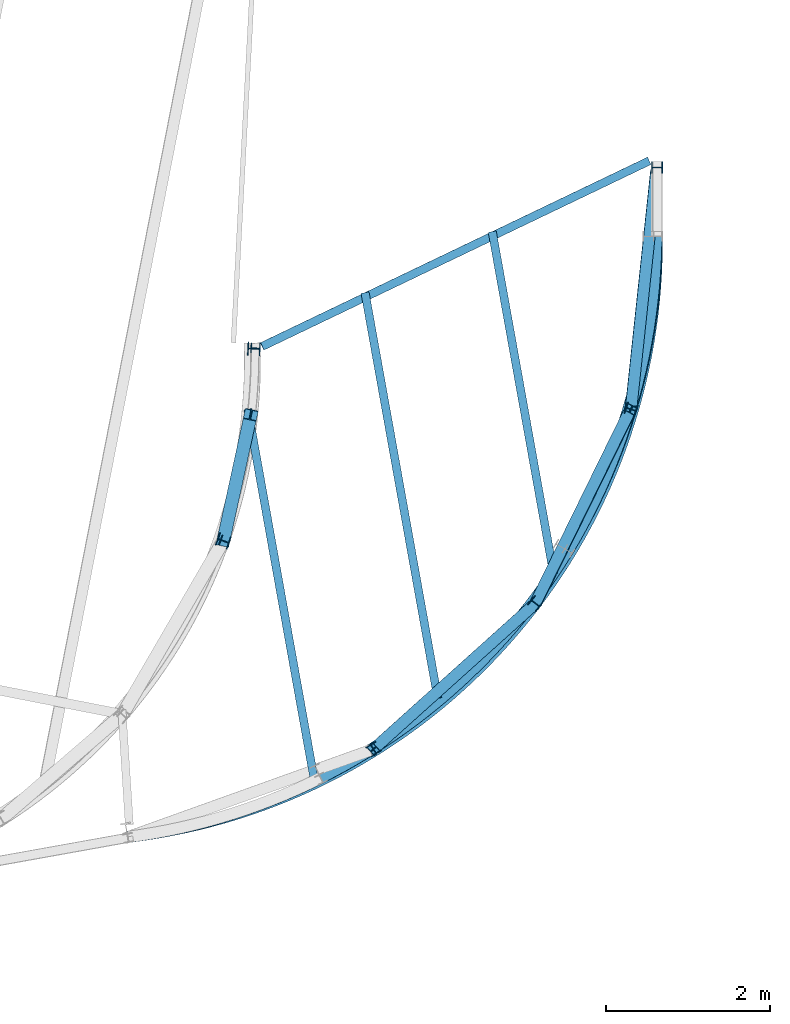
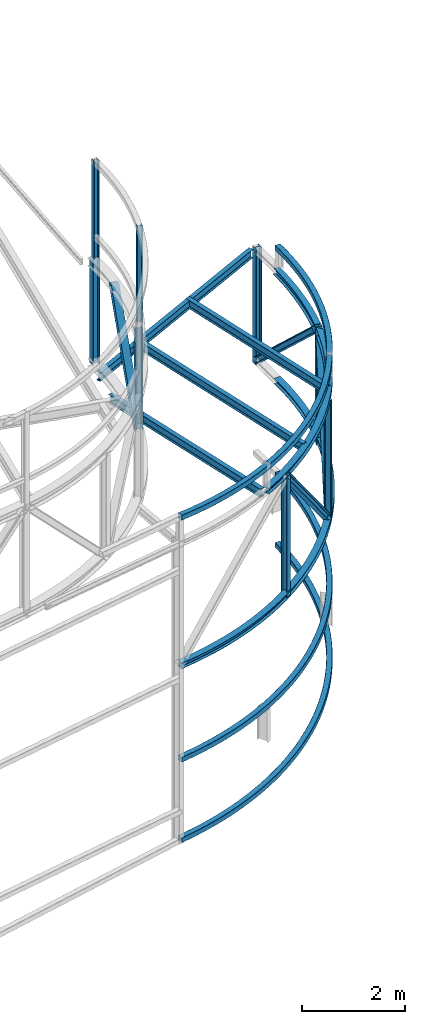
# One storey, part 103 of 215: 18 beams, 4 members, 22 elements without a shape of their own.
"""IFC2X3 building model written with IfcOpenShell, lengths in millimetres."""

from ifc_helpers import new_model, entity, si_unit, frame, origin_with_axes, origin_2d_with_axis, place, context, subcontext, project, spatial, i_section, extrude, material, type_object, element, aggregate, save


model = new_model("IFC2X3")

# Units and contexts
model_context = context("Model", 3, precision=1e-05, world=origin_with_axes())
body_context = subcontext(model_context, "Body", "Model", "MODEL_VIEW")
ifc_project = project(units=[si_unit("LENGTHUNIT", "METRE", prefix="MILLI"), si_unit("AREAUNIT", "SQUARE_METRE"), si_unit("VOLUMEUNIT", "CUBIC_METRE"), si_unit("MASSUNIT", "GRAM", prefix="KILO"), si_unit("TIMEUNIT", "SECOND"), si_unit("PLANEANGLEUNIT", "RADIAN"), si_unit("SOLIDANGLEUNIT", "STERADIAN"), si_unit("THERMODYNAMICTEMPERATUREUNIT", "DEGREE_CELSIUS"), si_unit("LUMINOUSINTENSITYUNIT", "LUMEN")], contexts=[model_context])

# Site, building, storey
site_placement = place(None, origin_with_axes())
site = spatial("IfcSite", under=ifc_project, at=site_placement, CompositionType="ELEMENT")
building_placement = place(site_placement, origin_with_axes())
building = spatial("IfcBuilding", under=site, at=building_placement, Name="Undefined", CompositionType="ELEMENT")
storey_placement = place(building_placement, origin_with_axes())
storey = spatial("IfcBuildingStorey", under=building, at=storey_placement, Name="Undefined", CompositionType="ELEMENT", Elevation=0.0)

# Assembly, beam
assembly_1_placement = place(storey_placement, origin_with_axes())
assembly_1 = element("IfcElementAssembly", 1, at=assembly_1_placement, inside=storey, Name="Steel Assembly", AssemblyPlace="NOTDEFINED", PredefinedType="RIGID_FRAME")
ifc_material = material(Name="STEEL/S275JR")
beam_type_1 = type_object("IfcBeamType", PredefinedType="NOTDEFINED")
beam_1_placement = place(assembly_1_placement, frame((103812.661912902, 11415.6337309544, 9570.9117512073), z_axis=(0.0238471140049326, 0.0280272360057927, 0.999322665206545), x_axis=(-0.657407552907123, -0.752636250893669, 0.0367965109948015)))
beam_1 = element("IfcBeam", 2, at=beam_1_placement, type_object=beam_type_1, material=ifc_material, Name="LISSE", context=body_context, shape_type="SweptSolid", body=[
    entity("IfcRevolvedAreaSolid", entity("IfcRectangleHollowProfileDef", "AREA", None, entity("IfcAxis2Placement2D", entity("IfcCartesianPoint", [0.0, 0.0]), entity("IfcDirection", [1.0, 0.0])), 120.0, 120.0, 4.0, 4.0, 8.0), entity("IfcAxis2Placement3D", entity("IfcCartesianPoint", [9816.76385710015, -1.33829753182288e-11, 3.63797880709171e-12]), entity("IfcDirection", [-0.751503806617227, 0.659728753837376, -1.25173885928287e-18]), entity("IfcDirection", [-0.659728753837376, -0.751503806617228, 1.42586860458967e-18])), entity("IfcAxis1Placement", entity("IfcCartesianPoint", [7440.0, 0.0, 0.0]), entity("IfcDirection", [0.0, 1.0, 0.0])), 1.44091553163659),
])
aggregate(assembly_1, [beam_1])

assembly_2_placement = place(storey_placement, origin_with_axes())
assembly_2 = element("IfcElementAssembly", 3, at=assembly_2_placement, inside=storey, Name="Steel Assembly", AssemblyPlace="NOTDEFINED", PredefinedType="RIGID_FRAME")
beam_type_2 = type_object("IfcBeamType", PredefinedType="NOTDEFINED")
beam_2_placement = place(assembly_2_placement, frame((97360.7958890832, 4029.22353778502, 4201.93969040489), z_axis=(-0.753149483126741, 0.657849332110703, -0.000335123000056234), x_axis=(0.657849249727944, 0.753149556688531, 0.00033149999986287)))
beam_2 = element("IfcBeam", 4, at=beam_2_placement, type_object=beam_type_2, material=ifc_material, Name="LISSE", context=body_context, shape_type="SweptSolid", body=[
    entity("IfcRevolvedAreaSolid", entity("IfcRectangleHollowProfileDef", "AREA", None, entity("IfcAxis2Placement2D", entity("IfcCartesianPoint", [0.0, 0.0]), entity("IfcDirection", [1.0, 0.0])), 120.0, 120.0, 5.0, 5.0, 10.0), entity("IfcAxis2Placement3D", entity("IfcCartesianPoint", [9809.51752939586, -1.06355002164056e-15, 1.2093029828155e-12]), entity("IfcDirection", [-0.751931040331638, 8.15245267486847e-20, -0.659241769448646]), entity("IfcDirection", [-6.93889390390723e-18, -1.0, -3.46944695195361e-18])), entity("IfcAxis1Placement", entity("IfcCartesianPoint", [0.0, 7440.0, 0.0]), entity("IfcDirection", [-1.0, 0.0, 0.0])), 1.43961987357017),
])
aggregate(assembly_2, [beam_2])

assembly_3_placement = place(storey_placement, origin_with_axes())
assembly_3 = element("IfcElementAssembly", 5, at=assembly_3_placement, inside=storey, Name="Steel Assembly", AssemblyPlace="NOTDEFINED", PredefinedType="RIGID_FRAME")
beam_3_placement = place(assembly_3_placement, frame((97359.8187777955, 4028.08994391259, 2298.41867692183), z_axis=(-0.753151991988058, 0.65784646798957, 0.000318618999995075), x_axis=(0.657653148961454, 0.752918744955869, 0.0246109559985575)))
beam_3 = element("IfcBeam", 6, at=beam_3_placement, type_object=beam_type_2, material=ifc_material, Name="LISSE", context=body_context, shape_type="SweptSolid", body=[
    entity("IfcRevolvedAreaSolid", entity("IfcRectangleHollowProfileDef", "AREA", None, entity("IfcAxis2Placement2D", entity("IfcCartesianPoint", [0.0, 0.0]), entity("IfcDirection", [1.0, 0.0])), 120.0, 120.0, 5.0, 5.0, 10.0), entity("IfcAxis2Placement3D", entity("IfcCartesianPoint", [9812.52919766532, -3.07016463649052e-13, -1.43585556658826e-11]), entity("IfcDirection", [-0.751753544225924, -2.89415736182007e-18, -0.659444166509767]), entity("IfcDirection", [-6.93889390390723e-18, -1.0, -3.46944695195361e-18])), entity("IfcAxis1Placement", entity("IfcCartesianPoint", [0.0, 7440.0, 0.0]), entity("IfcDirection", [-1.0, 0.0, 0.0])), 1.44015827653573),
])
aggregate(assembly_3, [beam_3])

# Assembly, member
assembly_4_placement = place(storey_placement, origin_with_axes())
assembly_4 = element("IfcElementAssembly", 7, at=assembly_4_placement, inside=storey, Name="Steel Assembly", AssemblyPlace="NOTDEFINED", PredefinedType="RIGID_FRAME")
member_type_1 = type_object("IfcMemberType", Name="HEA140", PredefinedType="NOTDEFINED")
member_1_placement = place(assembly_4_placement, frame((103801.363604508, 12197.8771549514, 6428.9296207433), z_axis=(0.0995443420180361, 0.662303576120042, 0.742593359134594), x_axis=(-0.078657430998341, -0.738727027984427, 0.669399272985889)))
member_1 = element("IfcMember", 8, at=member_1_placement, type_object=member_type_1, material=ifc_material, Name="LISSE", ObjectType="HEA140", context=body_context, shape_type="SweptSolid", body=[
    extrude(i_section(OverallWidth=140.0, OverallDepth=133.0, WebThickness=5.5, FlangeThickness=8.5, FilletRadius=12.0, at=origin_2d_with_axis()), frame((3988.20909249105, 1.46003443079458e-11, -6.64170234225445e-13), z_axis=(-1.0, 0.0, 0.0), x_axis=(-6.93889390390723e-18, -1.0, -3.46944695195361e-18)), (0.0, 0.0, 1.0), 3988.2),
])
aggregate(assembly_4, [member_1])

assembly_5_placement = place(storey_placement, origin_with_axes())
assembly_5 = element("IfcElementAssembly", 9, at=assembly_5_placement, inside=storey, Name="Steel Assembly", AssemblyPlace="NOTDEFINED", PredefinedType="RIGID_FRAME")
member_2_placement = place(assembly_5_placement, frame((102325.751087919, 6884.35829072175, 6427.24582166944), z_axis=(-0.354096459889119, -0.618141540806436, 0.70179536378024), x_axis=(0.309534081017408, 0.630656755035466, 0.711660530040022)))
member_2 = element("IfcMember", 10, at=member_2_placement, type_object=member_type_1, material=ifc_material, Name="LISSE", ObjectType="HEA140", context=body_context, shape_type="SweptSolid", body=[
    extrude(i_section(OverallWidth=140.0, OverallDepth=133.0, WebThickness=5.5, FlangeThickness=8.5, FilletRadius=12.0, at=origin_2d_with_axis()), frame((3753.73925143929, 2.89345262670774e-11, 0.0), z_axis=(-1.0, 0.0, 0.0), x_axis=(-6.93889390390723e-18, -1.0, -3.46944695195361e-18)), (0.0, 0.0, 1.0), 3753.7),
])
aggregate(assembly_5, [member_2])

assembly_6_placement = place(storey_placement, origin_with_axes())
assembly_6 = element("IfcElementAssembly", 11, at=assembly_6_placement, inside=storey, Name="Steel Assembly", AssemblyPlace="NOTDEFINED", PredefinedType="RIGID_FRAME")
member_3_placement = place(assembly_6_placement, frame((102325.751087919, 6884.35829072175, 6427.24582166944), z_axis=(0.540429476923553, 0.48199349993182, 0.689650814902447), x_axis=(-0.512855769123438, -0.461086949110978, 0.724139341174291)))
member_3 = element("IfcMember", 12, at=member_3_placement, type_object=member_type_1, material=ifc_material, Name="LISSE", ObjectType="HEA140", context=body_context, shape_type="SweptSolid", body=[
    extrude(i_section(OverallWidth=140.0, OverallDepth=133.0, WebThickness=5.5, FlangeThickness=8.5, FilletRadius=12.0, at=origin_2d_with_axis()), frame((3852.37348681223, -8.35350340725474e-14, -2.13849687225721e-13), z_axis=(-1.0, 0.0, 0.0), x_axis=(-6.93889390390723e-18, -1.0, -3.46944695195361e-18)), (0.0, 0.0, 1.0), 3852.4),
])
aggregate(assembly_6, [member_3])

# Assembly, beam
assembly_7_placement = place(storey_placement, origin_with_axes())
assembly_7 = element("IfcElementAssembly", 13, at=assembly_7_placement, inside=storey, Name="Steel Assembly", AssemblyPlace="NOTDEFINED", PredefinedType="RIGID_FRAME")
beam_type_3 = type_object("IfcBeamType", Name="HEA140", PredefinedType="NOTDEFINED")
beam_4_placement = place(assembly_7_placement, frame((103489.864532772, 9248.95634454911, 9098.64229158737), z_axis=(-0.949812800765097, 0.312818866922637, 0.0), x_axis=(0.0, 0.0, -1.0)))
beam_4 = element("IfcBeam", 14, at=beam_4_placement, type_object=beam_type_3, material=ifc_material, Name="MONTANT", ObjectType="HEA140", context=body_context, shape_type="SweptSolid", body=[
    extrude(i_section(OverallWidth=140.0, OverallDepth=133.0, WebThickness=5.5, FlangeThickness=8.5, FilletRadius=12.0, at=origin_2d_with_axis()), frame((2737.05596816904, 0.0, 0.0), z_axis=(-1.0, 0.0, 0.0), x_axis=(-6.93889390390723e-18, -1.0, -3.46944695195361e-18)), (0.0, 0.0, 1.0), 2737.1),
])
aggregate(assembly_7, [beam_4])

assembly_8_placement = place(storey_placement, origin_with_axes())
assembly_8 = element("IfcElementAssembly", 15, at=assembly_8_placement, inside=storey, Name="Steel Assembly", AssemblyPlace="NOTDEFINED", PredefinedType="RIGID_FRAME")
beam_5_placement = place(assembly_8_placement, frame((100350.681437564, 5108.80494933468, 9216.8944785472), z_axis=(-0.524501244037221, 0.851409681060421, 0.0), x_axis=(0.0, 0.0, -1.0)))
beam_5 = element("IfcBeam", 16, at=beam_5_placement, type_object=beam_type_3, material=ifc_material, Name="MONTANT", ObjectType="HEA140", context=body_context, shape_type="SweptSolid", body=[
    extrude(i_section(OverallWidth=140.0, OverallDepth=133.0, WebThickness=5.5, FlangeThickness=8.5, FilletRadius=12.0, at=origin_2d_with_axis()), frame((2857.05596125997, 0.0, 0.0), z_axis=(-1.0, 0.0, 0.0), x_axis=(-6.93889390390723e-18, -1.0, -3.46944695195361e-18)), (0.0, 0.0, 1.0), 2857.1),
])
aggregate(assembly_8, [beam_5])

assembly_9_placement = place(storey_placement, origin_with_axes())
assembly_9 = element("IfcElementAssembly", 17, at=assembly_9_placement, inside=storey, Name="Steel Assembly", AssemblyPlace="NOTDEFINED", PredefinedType="RIGID_FRAME")
beam_6_placement = place(assembly_9_placement, frame((102706.760333024, 7527.37509050482, 9185.02685536546), z_axis=(0.194085237016363, -0.0138701440011694, 0.980886609082665), x_axis=(0.267262959039298, 0.962823217141568, -0.0392678400057739)))
beam_6 = element("IfcBeam", 18, at=beam_6_placement, type_object=beam_type_3, material=ifc_material, Name="LISSE", ObjectType="HEA140", context=body_context, shape_type="SweptSolid", body=[
    entity("IfcRevolvedAreaSolid", entity("IfcIShapeProfileDef", "AREA", None, entity("IfcAxis2Placement2D", entity("IfcCartesianPoint", [0.0, 0.0]), entity("IfcDirection", [1.0, 0.0])), 140.0, 133.0, 5.5, 8.5, 12.0), entity("IfcAxis2Placement3D", entity("IfcCartesianPoint", [4034.32887668533, -1.43279649879765e-11, 3.6659725871405e-12]), entity("IfcDirection", [-0.962441498220801, -0.271489157246658, 8.3923962206943e-18]), entity("IfcDirection", [0.271489157246658, -0.962441498220801, 5.5310070017169e-17])), entity("IfcAxis1Placement", entity("IfcCartesianPoint", [-7430.0, 0.0, 0.0]), entity("IfcDirection", [-6.93889390390723e-18, -1.0, -3.46944695195361e-18])), 0.549879929951383),
])
aggregate(assembly_9, [beam_6])

assembly_10_placement = place(storey_placement, origin_with_axes())
assembly_10 = element("IfcElementAssembly", 19, at=assembly_10_placement, inside=storey, Name="Steel Assembly", AssemblyPlace="NOTDEFINED", PredefinedType="RIGID_FRAME")
beam_7_placement = place(assembly_10_placement, frame((99705.9289489224, 4758.38037052144, 9289.35776953744), z_axis=(0.0214764260015508, 0.018924140001372, 0.999590236072466), x_axis=(0.736038653281377, 0.676334308258553, -0.0286182520109403)))
beam_7 = element("IfcBeam", 20, at=beam_7_placement, type_object=beam_type_3, material=ifc_material, Name="LISSE", ObjectType="HEA140", context=body_context, shape_type="SweptSolid", body=[
    entity("IfcRevolvedAreaSolid", entity("IfcIShapeProfileDef", "AREA", None, entity("IfcAxis2Placement2D", entity("IfcCartesianPoint", [0.0, 0.0]), entity("IfcDirection", [1.0, 0.0])), 140.0, 133.0, 5.5, 8.5, 12.0), entity("IfcAxis2Placement3D", entity("IfcCartesianPoint", [4090.96071278785, -1.46757240240877e-13, 1.41933711755438e-14]), entity("IfcDirection", [-0.961358314825655, -0.275300182556383, -4.52930589916028e-18]), entity("IfcDirection", [0.275300182556383, -0.961358314825655, -3.2140877146414e-18])), entity("IfcAxis1Placement", entity("IfcCartesianPoint", [-7430.0, 0.0, 0.0]), entity("IfcDirection", [-6.93889390390723e-18, -1.0, -3.46944695195361e-18])), 0.557803873593897),
])
aggregate(assembly_10, [beam_7])

assembly_11_placement = place(storey_placement, origin_with_axes())
assembly_11 = element("IfcElementAssembly", 21, at=assembly_11_placement, inside=storey, Name="Steel Assembly", AssemblyPlace="NOTDEFINED", PredefinedType="RIGID_FRAME")
beam_8_placement = place(assembly_11_placement, frame((102325.766044717, 6884.37519160363, 9217.77752048577), z_axis=(-0.776046610750948, 0.630675556797603, 0.0), x_axis=(0.0, 0.0, -1.0)))
beam_8 = element("IfcBeam", 22, at=beam_8_placement, type_object=beam_type_3, material=ifc_material, Name="MONTANT", ObjectType="HEA140", context=body_context, shape_type="SweptSolid", body=[
    extrude(i_section(OverallWidth=140.0, OverallDepth=133.0, WebThickness=5.5, FlangeThickness=8.5, FilletRadius=12.0, at=origin_2d_with_axis()), frame((2857.05596125997, 0.0, 0.0), z_axis=(-1.0, 0.0, 0.0), x_axis=(-6.93889390390723e-18, -1.0, -3.46944695195361e-18)), (0.0, 0.0, 1.0), 2857.1),
])
aggregate(assembly_11, [beam_8])

assembly_12_placement = place(storey_placement, origin_with_axes())
assembly_12 = element("IfcElementAssembly", 23, at=assembly_12_placement, inside=storey, Name="Steel Assembly", AssemblyPlace="NOTDEFINED", PredefinedType="RIGID_FRAME")
beam_9_placement = place(assembly_12_placement, frame((103806.981319261, 12195.1440533534, 9116.87319085569), z_axis=(-1.0, 0.0, 0.0), x_axis=(0.0, 0.0, -1.0)))
beam_9 = element("IfcBeam", 24, at=beam_9_placement, type_object=beam_type_3, material=ifc_material, Name="MONTANT", ObjectType="HEA140", context=body_context, shape_type="SweptSolid", body=[
    extrude(i_section(OverallWidth=140.0, OverallDepth=133.0, WebThickness=5.5, FlangeThickness=8.5, FilletRadius=12.0, at=origin_2d_with_axis()), frame((2754.45233989554, 0.0, 0.0), z_axis=(-1.0, 0.0, 0.0), x_axis=(-6.93889390390723e-18, -1.0, -3.46944695195361e-18)), (0.0, 0.0, 1.0), 2754.5),
])
aggregate(assembly_12, [beam_9])

assembly_13_placement = place(storey_placement, origin_with_axes())
assembly_13 = element("IfcElementAssembly", 25, at=assembly_13_placement, inside=storey, Name="Steel Assembly", AssemblyPlace="NOTDEFINED", PredefinedType="RIGID_FRAME")
beam_10_placement = place(assembly_13_placement, frame((97357.0966623021, 4038.3527137283, 6425.48345017728), z_axis=(-0.000214563000003398, -0.00025287100000254, 0.999999945009487), x_axis=(0.658004642952018, 0.753013797945091, 0.000331598999975838)))
beam_10 = element("IfcBeam", 26, at=beam_10_placement, type_object=beam_type_3, material=ifc_material, Name="LISSE", ObjectType="HEA140", context=body_context, shape_type="SweptSolid", body=[
    entity("IfcRevolvedAreaSolid", entity("IfcIShapeProfileDef", "AREA", None, entity("IfcAxis2Placement2D", entity("IfcCartesianPoint", [0.0, 0.0]), entity("IfcDirection", [1.0, 0.0])), 140.0, 133.0, 5.5, 8.5, 12.0), entity("IfcAxis2Placement3D", entity("IfcCartesianPoint", [9797.66416470402, 1.55780406788781e-11, 1.81898940354586e-12]), entity("IfcDirection", [-0.741391380446362, -0.671072887993426, 2.72842006146973e-20]), entity("IfcDirection", [0.671072887993426, -0.741391380446362, 3.0143180450324e-20])), entity("IfcAxis1Placement", entity("IfcCartesianPoint", [-7300.0, 0.0, 0.0]), entity("IfcDirection", [-6.93889390390723e-18, -1.0, -3.46944695195361e-18])), 1.47130993821377),
])
aggregate(assembly_13, [beam_10])

assembly_14_placement = place(storey_placement, origin_with_axes())
assembly_14 = element("IfcElementAssembly", 27, at=assembly_14_placement, inside=storey, Name="Steel Assembly", AssemblyPlace="NOTDEFINED", PredefinedType="RIGID_FRAME")
beam_type_4 = type_object("IfcBeamType", Name="HEA120", PredefinedType="NOTDEFINED")
beam_11_placement = place(assembly_14_placement, frame((98539.3216124034, 7640.44236125411, 14219.9969989988), z_axis=(-0.942164761937855, 0.335150057977894, -1.0000003384698e-09), x_axis=(0.0, 0.0, -1.0)))
beam_11 = element("IfcBeam", 28, at=beam_11_placement, type_object=beam_type_4, material=ifc_material, ObjectType="HEA120", context=body_context, shape_type="SweptSolid", body=[
    extrude(i_section(OverallWidth=120.0, OverallDepth=114.0, WebThickness=5.0, FlangeThickness=8.0, FilletRadius=12.0, at=origin_2d_with_axis()), frame((2281.04039032749, 0.0, 0.0), z_axis=(-1.0, 0.0, 0.0), x_axis=(-6.93889390390723e-18, -1.0, -3.46944695195361e-18)), (0.0, 0.0, 1.0), 2281.0),
])
aggregate(assembly_14, [beam_11])

assembly_15_placement = place(storey_placement, origin_with_axes())
assembly_15 = element("IfcElementAssembly", 29, at=assembly_15_placement, inside=storey, Name="Steel Assembly", AssemblyPlace="NOTDEFINED", PredefinedType="RIGID_FRAME")
beam_12_placement = place(assembly_15_placement, frame((98913.6969427392, 9995.35567043154, 14219.9969990767), z_axis=(-0.998587881730484, 0.0531247819856622, -1.00000033826585e-09), x_axis=(0.0, 0.0, -1.0)))
beam_12 = element("IfcBeam", 30, at=beam_12_placement, type_object=beam_type_4, material=ifc_material, Name="POTEAU", ObjectType="HEA120", context=body_context, shape_type="SweptSolid", body=[
    extrude(i_section(OverallWidth=120.0, OverallDepth=114.0, WebThickness=5.0, FlangeThickness=8.0, FilletRadius=12.0, at=origin_2d_with_axis()), frame((2314.77327351045, 0.0, 0.0), z_axis=(-1.0, 0.0, 0.0), x_axis=(-6.93889390390723e-18, -1.0, -3.46944695195361e-18)), (0.0, 0.0, 1.0), 2314.8),
])
aggregate(assembly_15, [beam_12])

assembly_16_placement = place(storey_placement, origin_with_axes())
assembly_16 = element("IfcElementAssembly", 31, at=assembly_16_placement, inside=storey, Name="Steel Assembly", AssemblyPlace="NOTDEFINED", PredefinedType="RIGID_FRAME")
beam_type_5 = type_object("IfcBeamType", Name="IPE200", PredefinedType="NOTDEFINED")
beam_13_placement = place(assembly_16_placement, frame((101134.59672062, 5731.58461982217, 9217.9277335535), z_axis=(-0.00698864299976025, 0.03895139699864, 0.999216666965116), x_axis=(-0.176461277084685, 0.983511751471997, -0.0395733800189916)))
beam_13 = element("IfcBeam", 32, at=beam_13_placement, type_object=beam_type_5, material=ifc_material, ObjectType="IPE200", context=body_context, shape_type="SweptSolid", body=[
    extrude(i_section(OverallWidth=100.0, OverallDepth=200.0, WebThickness=5.599999905, FlangeThickness=8.5, FilletRadius=12.0, at=origin_2d_with_axis()), frame((5019.30596819177, 1.14382089951286e-13, 1.78416097196133e-12), z_axis=(-1.0, 0.0, 0.0), x_axis=(-6.93889390390723e-18, -1.0, -3.46944695195361e-18)), (0.0, 0.0, 1.0), 5019.3),
])
aggregate(assembly_16, [beam_13])

assembly_17_placement = place(storey_placement, origin_with_axes())
assembly_17 = element("IfcElementAssembly", 33, at=assembly_17_placement, inside=storey, Name="Steel Assembly", AssemblyPlace="NOTDEFINED", PredefinedType="RIGID_FRAME")
beam_14_placement = place(assembly_17_placement, frame((102546.812622736, 7244.54299409441, 9154.05694400393), z_axis=(-0.00683459499782489, 0.0380887899879171, 0.999250985683013), x_axis=(-0.17648535903817, 0.983542297212716, -0.0386971270083694)))
beam_14 = element("IfcBeam", 34, at=beam_14_placement, type_object=beam_type_5, material=ifc_material, ObjectType="IPE200", context=body_context, shape_type="SweptSolid", body=[
    extrude(i_section(OverallWidth=100.0, OverallDepth=200.0, WebThickness=5.599999905, FlangeThickness=8.5, FilletRadius=12.0, at=origin_2d_with_axis()), frame((4236.37099602429, 1.46899672297823e-11, -1.81898940354586e-12), z_axis=(-1.0, 0.0, 0.0), x_axis=(-6.93889390390723e-18, -1.0, -3.46944695195361e-18)), (0.0, 0.0, 1.0), 4236.4),
])
aggregate(assembly_17, [beam_14])

assembly_18_placement = place(storey_placement, origin_with_axes())
assembly_18 = element("IfcElementAssembly", 35, at=assembly_18_placement, inside=storey, Name="Steel Assembly", AssemblyPlace="NOTDEFINED", PredefinedType="RIGID_FRAME")
beam_15_placement = place(assembly_18_placement, frame((99626.2870139812, 4752.77893296209, 9263.15249124332), z_axis=(-0.00739704499956348, 0.0412356529975375, 0.999122066940342), x_axis=(-0.176411334004075, 0.983424601022721, -0.0418938580009678)))
beam_15 = element("IfcBeam", 36, at=beam_15_placement, type_object=beam_type_5, material=ifc_material, ObjectType="IPE200", context=body_context, shape_type="SweptSolid", body=[
    extrude(i_section(OverallWidth=100.0, OverallDepth=200.0, WebThickness=5.599999905, FlangeThickness=8.5, FilletRadius=12.0, at=origin_2d_with_axis()), frame((4571.04213713568, -9.68633188613053e-15, -1.85070737996573e-12), z_axis=(-1.0, 0.0, 0.0), x_axis=(-6.93889390390723e-18, -1.0, -3.46944695195361e-18)), (0.0, 0.0, 1.0), 4571.0),
])
aggregate(assembly_18, [beam_15])

assembly_19_placement = place(storey_placement, origin_with_axes())
assembly_19 = element("IfcElementAssembly", 37, at=assembly_19_placement, inside=storey, Name="Steel Assembly", AssemblyPlace="NOTDEFINED", PredefinedType="RIGID_FRAME")
beam_16_placement = place(assembly_19_placement, frame((98994.3505096132, 10016.4637543883, 9041.42240088784), z_axis=(0.0158992389954929, 0.00608290799827373, 0.999855095716199), x_axis=(0.901614465519492, 0.432207696249029, -0.0169665220097759)))
beam_16 = element("IfcBeam", 38, at=beam_16_placement, type_object=beam_type_5, material=ifc_material, ObjectType="IPE200", context=body_context, shape_type="SweptSolid", body=[
    extrude(i_section(OverallWidth=100.0, OverallDepth=200.0, WebThickness=5.599999905, FlangeThickness=8.5, FilletRadius=12.0, at=origin_2d_with_axis()), frame((5231.02168339805, -2.43377603214808e-13, -1.81487522350687e-14), z_axis=(-1.0, 0.0, 0.0), x_axis=(-6.93889390390723e-18, -1.0, -3.46944695195361e-18)), (0.0, 0.0, 1.0), 5231.0),
])
aggregate(assembly_19, [beam_16])

assembly_20_placement = place(storey_placement, origin_with_axes())
assembly_20 = element("IfcElementAssembly", 39, at=assembly_20_placement, inside=storey, Name="Steel Assembly", AssemblyPlace="NOTDEFINED", PredefinedType="RIGID_FRAME")
beam_type_6 = type_object("IfcBeamType", Name="HEA160", PredefinedType="NOTDEFINED")
beam_17_placement = place(assembly_20_placement, frame((98894.1873976397, 9986.30802120351, 11903.9339001552), z_axis=(-0.998589309891872, 0.0530979299942507, 0.0), x_axis=(0.0, 0.0, -1.0)))
beam_17 = element("IfcBeam", 40, at=beam_17_placement, type_object=beam_type_6, material=ifc_material, Name="MONTANT", ObjectType="HEA160", context=body_context, shape_type="SweptSolid", body=[
    extrude(i_section(OverallWidth=160.0, OverallDepth=152.0, WebThickness=6.0, FlangeThickness=9.0, FilletRadius=15.0, at=origin_2d_with_axis()), frame((2495.41423852867, 0.0, 0.0), z_axis=(-1.0, 0.0, 0.0), x_axis=(-6.93889390390723e-18, -1.0, -3.46944695195361e-18)), (0.0, 0.0, 1.0), 2495.4),
])
aggregate(assembly_20, [beam_17])

assembly_21_placement = place(storey_placement, origin_with_axes())
assembly_21 = element("IfcElementAssembly", 41, at=assembly_21_placement, inside=storey, Name="Steel Assembly", AssemblyPlace="NOTDEFINED", PredefinedType="RIGID_FRAME")
beam_18_placement = place(assembly_21_placement, frame((98521.3989007489, 7646.72849056096, 11804.2532980108), z_axis=(-0.942212473960407, 0.335015900985922, 0.0), x_axis=(0.0, 0.0, -1.0)))
beam_18 = element("IfcBeam", 42, at=beam_18_placement, type_object=beam_type_6, material=ifc_material, Name="MONTANT", ObjectType="HEA160", context=body_context, shape_type="SweptSolid", body=[
    extrude(i_section(OverallWidth=160.0, OverallDepth=152.0, WebThickness=6.0, FlangeThickness=9.0, FilletRadius=15.0, at=origin_2d_with_axis()), frame((2395.82950477546, 0.0, 0.0), z_axis=(-1.0, 0.0, 0.0), x_axis=(-6.93889390390723e-18, -1.0, -3.46944695195361e-18)), (0.0, 0.0, 1.0), 2395.8),
])
aggregate(assembly_21, [beam_18])

# Assembly, member
assembly_22_placement = place(storey_placement, origin_with_axes())
assembly_22 = element("IfcElementAssembly", 43, at=assembly_22_placement, inside=storey, Name="Steel Assembly", AssemblyPlace="NOTDEFINED", PredefinedType="RIGID_FRAME")
member_type_2 = type_object("IfcMemberType", Name="HEA160", PredefinedType="NOTDEFINED")
member_4_placement = place(assembly_22_placement, frame((98855.6600782685, 9183.85254325932, 11838.3126093064), z_axis=(-0.178376782043288, -0.820278457199032, 0.543438107131859), x_axis=(-0.115476596007104, -0.531027431032661, -0.839449238051631)))
member_4 = element("IfcMember", 44, at=member_4_placement, type_object=member_type_2, material=ifc_material, Name="LISSE", ObjectType="HEA160", context=body_context, shape_type="SweptSolid", body=[
    extrude(i_section(OverallWidth=160.0, OverallDepth=152.0, WebThickness=6.0, FlangeThickness=9.0, FilletRadius=15.0, at=origin_2d_with_axis()), frame((2894.62269423727, -3.61253252554734e-14, -3.63797880709171e-12), z_axis=(-1.0, 0.0, 0.0), x_axis=(-6.93889390390723e-18, -1.0, -3.46944695195361e-18)), (0.0, 0.0, 1.0), 2894.6),
])
aggregate(assembly_22, [member_4])

save(model, "model.ifc")
